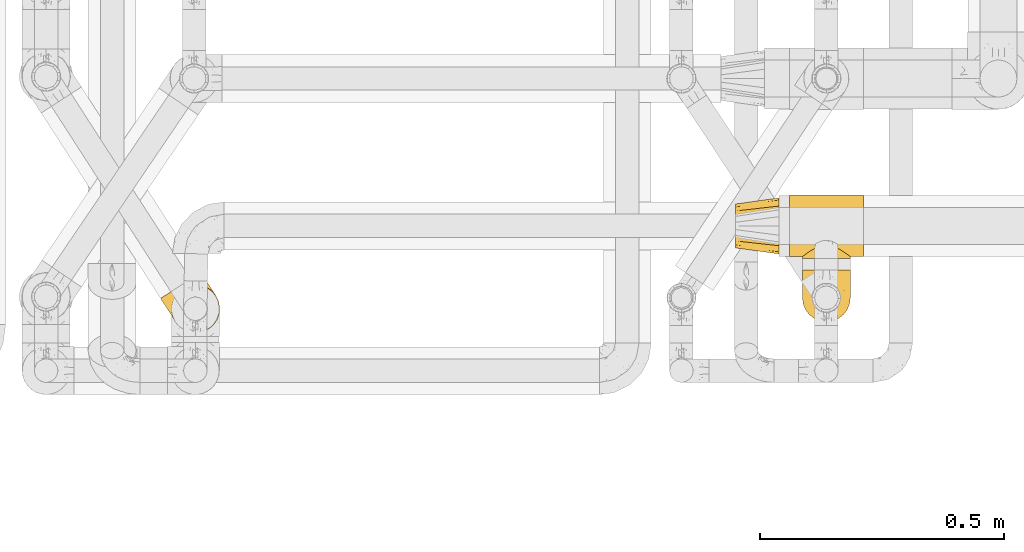
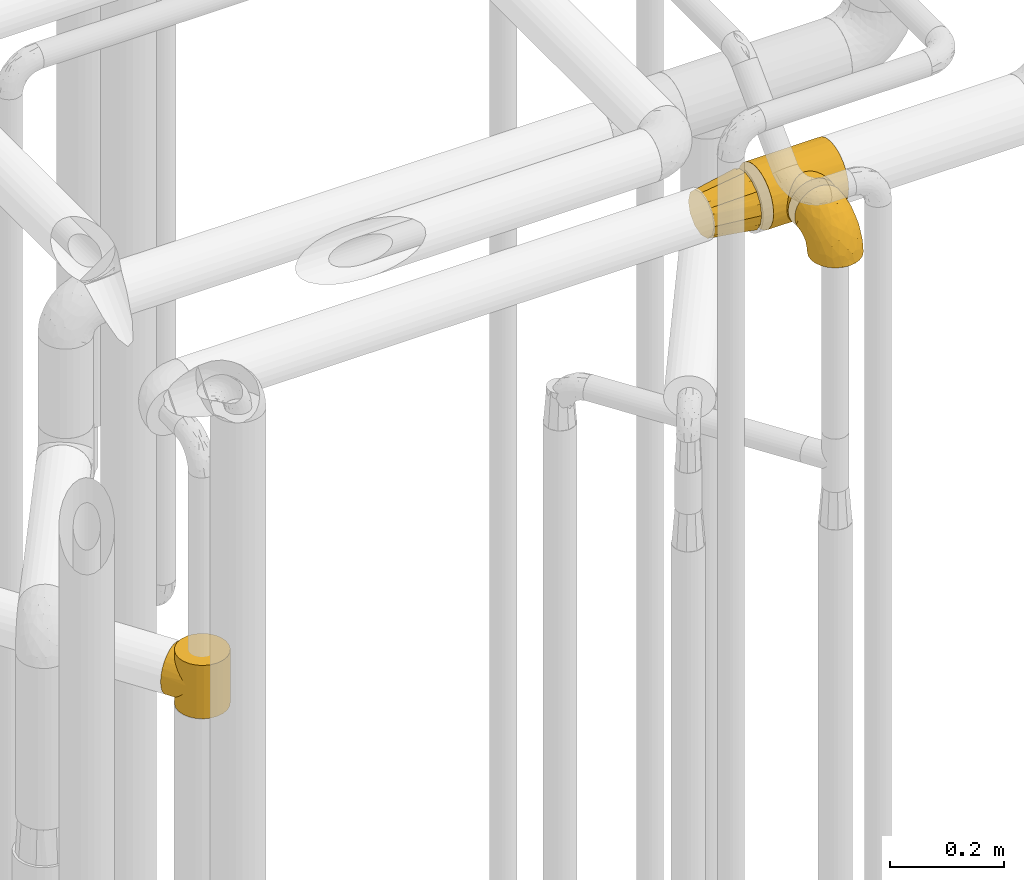
# One storey, part 388 of 827: 4 coverings.
"""IFC2X3 building model written with IfcOpenShell, lengths in millimetres."""

from ifc_helpers import new_model, entity, si_unit, converted_unit, derived_unit, direction, frame, origin, place, context, subcontext, project, spatial, faceted_brep, element, save


model = new_model("IFC2X3")

# Units and contexts
model_context = context("Model", 3, precision=0.01, world=origin(), true_north=direction((6.12303176911189e-17, 1.0)))
body_context = subcontext(model_context, "Body", "Model", "MODEL_VIEW")
ifc_project = project(units=[si_unit("LENGTHUNIT", "METRE", prefix="MILLI"), si_unit("AREAUNIT", "SQUARE_METRE"), si_unit("VOLUMEUNIT", "CUBIC_METRE"), converted_unit("PLANEANGLEUNIT", "DEGREE", entity("IfcRatioMeasure", 0.0174532925199433), si_unit("PLANEANGLEUNIT", "RADIAN"), dimensions=[0, 0, 0, 0, 0, 0, 0]), si_unit("MASSUNIT", "GRAM", prefix="KILO"), derived_unit("MASSDENSITYUNIT", [(si_unit("MASSUNIT", "GRAM", prefix="KILO"), 1), (si_unit("LENGTHUNIT", "METRE"), -3)]), derived_unit("MOMENTOFINERTIAUNIT", [(si_unit("LENGTHUNIT", "METRE"), 4)]), si_unit("TIMEUNIT", "SECOND"), si_unit("FREQUENCYUNIT", "HERTZ"), si_unit("THERMODYNAMICTEMPERATUREUNIT", "DEGREE_CELSIUS"), derived_unit("THERMALTRANSMITTANCEUNIT", [(si_unit("MASSUNIT", "GRAM", prefix="KILO"), 1), (si_unit("THERMODYNAMICTEMPERATUREUNIT", "KELVIN"), -1), (si_unit("TIMEUNIT", "SECOND"), -3)]), derived_unit("VOLUMETRICFLOWRATEUNIT", [(si_unit("LENGTHUNIT", "METRE"), 3), (si_unit("TIMEUNIT", "SECOND"), -1)]), derived_unit("MASSFLOWRATEUNIT", [(si_unit("MASSUNIT", "GRAM", prefix="KILO"), 1), (si_unit("TIMEUNIT", "SECOND"), -1)]), derived_unit("ROTATIONALFREQUENCYUNIT", [(si_unit("TIMEUNIT", "SECOND"), -1)]), si_unit("ELECTRICCURRENTUNIT", "AMPERE"), si_unit("ELECTRICVOLTAGEUNIT", "VOLT"), si_unit("POWERUNIT", "WATT"), si_unit("FORCEUNIT", "NEWTON", prefix="KILO"), si_unit("ILLUMINANCEUNIT", "LUX"), si_unit("LUMINOUSFLUXUNIT", "LUMEN"), si_unit("LUMINOUSINTENSITYUNIT", "CANDELA"), derived_unit("USERDEFINED", [(si_unit("MASSUNIT", "GRAM", prefix="KILO"), -1), (si_unit("LENGTHUNIT", "METRE"), -2), (si_unit("TIMEUNIT", "SECOND"), 3), (si_unit("LUMINOUSFLUXUNIT", "LUMEN"), 1)]), derived_unit("LINEARVELOCITYUNIT", [(si_unit("LENGTHUNIT", "METRE"), 1), (si_unit("TIMEUNIT", "SECOND"), -1)]), si_unit("PRESSUREUNIT", "PASCAL"), derived_unit("USERDEFINED", [(si_unit("LENGTHUNIT", "METRE"), -2), (si_unit("MASSUNIT", "GRAM", prefix="KILO"), 1), (si_unit("TIMEUNIT", "SECOND"), -2)]), derived_unit("LINEARFORCEUNIT", [(si_unit("MASSUNIT", "GRAM", prefix="KILO"), 1), (si_unit("LENGTHUNIT", "METRE"), 1), (si_unit("TIMEUNIT", "SECOND"), -2), (si_unit("LENGTHUNIT", "METRE"), -1)]), derived_unit("PLANARFORCEUNIT", [(si_unit("MASSUNIT", "GRAM", prefix="KILO"), 1), (si_unit("LENGTHUNIT", "METRE"), 1), (si_unit("TIMEUNIT", "SECOND"), -2), (si_unit("LENGTHUNIT", "METRE"), -2)])], contexts=[model_context])

# Site, building, storey
site_placement = place(None, origin())
site = spatial("IfcSite", under=ifc_project, at=site_placement, CompositionType="ELEMENT")
building_placement = place(site_placement, origin())
building = spatial("IfcBuilding", under=site, at=building_placement, CompositionType="ELEMENT")
storey_placement = place(building_placement, frame((0.0, 0.0, 28200.0)))
storey = spatial("IfcBuildingStorey", under=building, at=storey_placement, Name="08", CompositionType="ELEMENT", Elevation=28200.0)

# Coverings
covering_1_placement = place(storey_placement, frame((48106.03, 13874.41, 2538.4)))
element("IfcCovering", 1, at=covering_1_placement, inside=storey, Name=":ADSK_", ObjectType=":ADSK_", PredefinedType="INSULATION", context=body_context, shape_type="Brep", body=[
    faceted_brep([(0.0, 104.1, 59.1), (0.0, 101.08, 47.85), (0.0, 98.07, 36.6), (0.0, 89.83, 28.36), (0.0, 81.6, 20.12), (0.0, 70.35, 17.11), (0.0, 59.1, 14.1), (0.0, 47.85, 17.11), (0.0, 36.6, 20.12), (0.0, 28.36, 28.36), (0.0, 20.12, 36.6), (0.0, 17.11, 47.85), (0.0, 14.1, 59.1), (0.0, 17.11, 70.35), (0.0, 20.12, 81.6), (0.0, 28.36, 89.83), (0.0, 36.6, 98.07), (0.0, 47.85, 101.08), (0.0, 59.1, 104.1), (0.0, 70.35, 101.08), (0.0, 81.6, 98.07), (0.0, 89.83, 89.83), (0.0, 98.07, 81.6), (0.0, 101.08, 70.35), (89.0, 5.97, 81.1), (89.0, 3.78, 70.1), (89.0, 1.6, 59.1), (89.0, 3.78, 48.09), (89.0, 5.97, 37.09), (89.0, 12.2, 27.76), (89.0, 18.44, 18.44), (89.0, 27.76, 12.2), (89.0, 37.09, 5.97), (89.0, 48.09, 3.78), (89.0, 59.1, 1.6), (89.0, 70.1, 3.78), (89.0, 81.1, 5.97), (89.0, 90.43, 12.2), (89.0, 99.75, 18.44), (89.0, 105.99, 27.76), (89.0, 112.22, 37.09), (89.0, 114.41, 48.09), (89.0, 116.6, 59.1), (89.0, 114.41, 70.1), (89.0, 112.22, 81.1), (89.0, 105.99, 90.43), (89.0, 99.75, 99.75), (89.0, 90.43, 105.99), (89.0, 81.1, 112.22), (89.0, 70.1, 114.41), (89.0, 59.1, 116.6), (89.0, 48.09, 114.41), (89.0, 37.09, 112.22), (89.0, 27.76, 105.99), (89.0, 18.44, 99.75), (89.0, 12.2, 90.43)], [[[0, 1, 2, 3, 4, 5, 6, 7, 8, 9, 10, 11, 12, 13, 14, 15, 16, 17, 18, 19, 20, 21, 22, 23]], [[24, 25, 26, 27, 28, 29, 30, 31, 32, 33, 34, 35, 36, 37, 38, 39, 40, 41, 42, 43, 44, 45, 46, 47, 48, 49, 50, 51, 52, 53, 54, 55]], [[35, 34, 6]], [[2, 40, 39]], [[37, 36, 4]], [[37, 4, 3]], [[2, 39, 3]], [[37, 3, 38]], [[41, 40, 1]], [[6, 5, 35]], [[39, 38, 3]], [[0, 41, 1]], [[5, 4, 36]], [[41, 0, 42]], [[40, 2, 1]], [[5, 36, 35]], [[27, 26, 12]], [[8, 32, 31]], [[29, 28, 10]], [[29, 10, 9]], [[8, 31, 9]], [[29, 9, 30]], [[33, 32, 7]], [[12, 11, 27]], [[31, 30, 9]], [[6, 33, 7]], [[11, 10, 28]], [[33, 6, 34]], [[32, 8, 7]], [[11, 28, 27]], [[51, 50, 18]], [[14, 24, 55]], [[53, 52, 16]], [[53, 16, 15]], [[14, 55, 15]], [[53, 15, 54]], [[25, 24, 13]], [[18, 17, 51]], [[55, 54, 15]], [[12, 25, 13]], [[17, 16, 52]], [[25, 12, 26]], [[24, 14, 13]], [[17, 52, 51]], [[43, 42, 0]], [[20, 48, 47]], [[45, 44, 22]], [[45, 22, 21]], [[20, 47, 21]], [[45, 21, 46]], [[49, 48, 19]], [[0, 23, 43]], [[47, 46, 21]], [[18, 49, 19]], [[23, 22, 44]], [[49, 18, 50]], [[48, 20, 19]], [[23, 44, 43]]]),
])
covering_2_placement = place(storey_placement, frame((48216.02, 13866.51, 2532.85)))
element("IfcCovering", 2, at=covering_2_placement, inside=storey, Name=":ADSK_", ObjectType=":ADSK_", PredefinedType="INSULATION", context=body_context, shape_type="Brep", body=[
    faceted_brep([(152.0, 121.6, 33.12), (152.0, 127.9, 48.33), (152.0, 130.05, 64.65), (152.0, 127.9, 80.96), (152.0, 121.6, 96.17), (152.0, 111.58, 109.23), (152.0, 98.53, 119.25), (152.0, 83.32, 125.55), (152.0, 67.0, 127.7), (152.0, 50.68, 125.55), (152.0, 35.48, 119.25), (152.0, 22.42, 109.23), (152.0, 17.41, 102.7), (152.0, 12.4, 96.17), (152.0, 9.25, 88.57), (152.0, 6.1, 80.96), (152.0, 5.02, 72.8), (152.0, 3.95, 64.65), (152.0, 5.02, 56.49), (152.0, 6.1, 48.33), (152.0, 9.25, 40.72), (152.0, 12.4, 33.12), (152.0, 17.41, 26.59), (152.0, 22.42, 20.06), (152.0, 35.48, 10.04), (152.0, 50.68, 3.74), (152.0, 67.0, 1.6), (152.0, 83.32, 3.74), (152.0, 98.53, 10.04), (152.0, 111.58, 20.06), (0.0, 67.0, 127.7), (0.0, 83.32, 125.55), (0.0, 98.53, 119.25), (0.0, 111.58, 109.23), (0.0, 121.6, 96.17), (0.0, 127.9, 80.96), (0.0, 130.05, 64.65), (0.0, 127.9, 48.33), (0.0, 121.6, 33.12), (0.0, 111.58, 20.06), (0.0, 98.53, 10.04), (0.0, 83.32, 3.74), (0.0, 67.0, 1.6), (0.0, 50.68, 3.74), (0.0, 35.48, 10.04), (0.0, 22.42, 20.06), (0.0, 17.41, 26.59), (0.0, 12.4, 33.12), (0.0, 9.25, 40.72), (0.0, 6.1, 48.33), (0.0, 5.02, 56.49), (0.0, 3.95, 64.65), (0.0, 5.02, 72.8), (0.0, 6.1, 80.96), (0.0, 9.25, 88.57), (0.0, 12.4, 96.17), (0.0, 17.41, 102.7), (0.0, 22.42, 109.23), (0.0, 35.48, 119.25), (0.0, 50.68, 125.55), (45.43, 17.06, 103.13), (54.33, 21.96, 108.76), (37.94, 12.15, 95.74), (119.94, 7.92, 86.67), (64.61, 25.9, 112.46), (76.0, 27.51, 113.8), (87.39, 25.9, 112.46), (124.47, 4.48, 70.38), (125.15, 3.95, 64.65), (26.85, 3.95, 64.65), (27.53, 4.48, 70.38), (106.57, 17.06, 103.13), (97.67, 21.96, 108.76), (114.06, 12.15, 95.74), (32.06, 7.92, 86.67), (121.87, 6.46, 81.39), (123.79, 5.0, 76.12), (28.21, 5.0, 76.12), (30.13, 6.46, 81.39), (27.53, 4.48, 58.91), (28.21, 5.0, 53.17), (37.94, 12.15, 33.55), (32.06, 7.92, 42.62), (30.13, 6.46, 47.9), (123.79, 5.0, 53.17), (124.47, 4.48, 58.91), (114.06, 12.15, 33.55), (119.94, 7.92, 42.62), (106.57, 17.06, 26.16), (121.87, 6.46, 47.9), (45.43, 17.06, 26.16), (54.33, 21.96, 20.53), (64.61, 25.9, 16.83), (76.0, 27.51, 15.5), (97.67, 21.96, 20.53), (87.39, 25.9, 16.83), (63.28, 0.0, 112.12), (51.43, 0.0, 107.21), (41.25, 0.0, 99.4), (33.43, 0.0, 89.22), (30.98, 0.0, 83.29), (28.52, 0.0, 77.37), (27.69, 0.0, 71.01), (26.85, 0.0, 64.65), (27.69, 0.0, 58.28), (28.52, 0.0, 51.92), (30.98, 0.0, 46.0), (33.43, 0.0, 40.07), (41.25, 0.0, 29.89), (51.43, 0.0, 22.08), (63.28, 0.0, 17.17), (76.0, 0.0, 15.5), (88.72, 0.0, 17.17), (100.58, 0.0, 22.08), (110.75, 0.0, 29.89), (118.57, 0.0, 40.07), (121.02, 0.0, 46.0), (123.48, 0.0, 51.92), (124.31, 0.0, 58.28), (125.15, 0.0, 64.65), (124.31, 0.0, 71.01), (123.48, 0.0, 77.37), (121.02, 0.0, 83.29), (118.57, 0.0, 89.22), (110.75, 0.0, 99.4), (100.58, 0.0, 107.21), (88.72, 0.0, 112.12), (76.0, 0.0, 113.8)], [[[0, 1, 2, 3, 4, 5, 6, 7, 8, 9, 10, 11, 12, 13, 14, 15, 16, 17, 18, 19, 20, 21, 22, 23, 24, 25, 26, 27, 28, 29]], [[30, 31, 32, 33, 34, 35, 36, 37, 38, 39, 40, 41, 42, 43, 44, 45, 46, 47, 48, 49, 50, 51, 52, 53, 54, 55, 56, 57, 58, 59]], [[34, 33, 5, 4]], [[2, 36, 35, 3]], [[4, 3, 35, 34]], [[6, 32, 31, 7]], [[7, 31, 30, 8]], [[5, 33, 32, 6]], [[59, 9, 8, 30]], [[58, 10, 9, 59]], [[57, 60, 61]], [[56, 55, 62]], [[63, 15, 14]], [[61, 64, 57]], [[60, 57, 56]], [[57, 64, 58]], [[64, 65, 58]], [[66, 11, 10]], [[17, 67, 68]], [[69, 70, 51]], [[71, 11, 72]], [[72, 11, 66]], [[73, 12, 71]], [[66, 10, 65]], [[65, 10, 58]], [[62, 54, 74]], [[54, 62, 55]], [[74, 54, 53]], [[15, 63, 75, 76]], [[77, 53, 52]], [[51, 70, 52]], [[77, 52, 70]], [[53, 77, 78, 74]], [[73, 13, 12]], [[73, 14, 13]], [[14, 73, 63]], [[16, 76, 67]], [[71, 12, 11]], [[17, 16, 67]], [[16, 15, 76]], [[60, 56, 62]], [[50, 79, 51]], [[80, 50, 49]], [[47, 81, 48]], [[82, 48, 81]], [[82, 49, 48]], [[49, 82, 83, 80]], [[50, 80, 79]], [[84, 18, 85]], [[85, 17, 68]], [[51, 79, 69]], [[86, 21, 20]], [[17, 85, 18]], [[20, 19, 87]], [[86, 88, 22]], [[87, 19, 84, 89]], [[81, 46, 90]], [[81, 47, 46]], [[90, 45, 91]], [[45, 90, 46]], [[91, 45, 92]], [[24, 44, 43, 25]], [[93, 92, 44]], [[44, 92, 45]], [[43, 42, 26, 25]], [[84, 19, 18]], [[94, 95, 23]], [[86, 20, 87]], [[22, 21, 86]], [[23, 88, 94]], [[95, 24, 23]], [[93, 24, 95]], [[93, 44, 24]], [[88, 23, 22]], [[27, 41, 40, 28]], [[28, 40, 39, 29]], [[42, 41, 27, 26]], [[0, 38, 37, 1]], [[1, 37, 36, 2]], [[29, 39, 38, 0]], [[96, 97, 98, 99, 100, 101, 102, 103, 104, 105, 106, 107, 108, 109, 110, 111, 112, 113, 114, 115, 116, 117, 118, 119, 120, 121, 122, 123, 124, 125, 126, 127]], [[77, 102, 101]], [[74, 100, 99]], [[103, 70, 69]], [[103, 102, 70]], [[101, 78, 77]], [[62, 74, 99]], [[100, 78, 101]], [[100, 74, 78]], [[99, 98, 62]], [[60, 98, 97]], [[96, 127, 64]], [[102, 77, 70]], [[61, 97, 96]], [[60, 97, 61]], [[64, 61, 96]], [[65, 64, 127]], [[98, 60, 62]], [[66, 127, 126]], [[72, 126, 125]], [[65, 127, 66]], [[119, 67, 120]], [[66, 126, 72]], [[125, 71, 72]], [[125, 124, 71]], [[73, 124, 123]], [[76, 75, 121]], [[67, 119, 68]], [[76, 121, 120]], [[63, 73, 123]], [[63, 123, 122]], [[76, 120, 67]], [[122, 75, 63]], [[121, 75, 122]], [[124, 73, 71]], [[84, 118, 117]], [[87, 116, 115]], [[119, 85, 68]], [[119, 118, 85]], [[117, 89, 84]], [[86, 87, 115]], [[116, 89, 117]], [[118, 84, 85]], [[115, 114, 86]], [[88, 114, 113]], [[113, 112, 94]], [[111, 95, 112]], [[116, 87, 89]], [[88, 113, 94]], [[95, 94, 112]], [[93, 95, 111]], [[114, 88, 86]], [[92, 111, 110]], [[91, 110, 109]], [[93, 111, 92]], [[103, 79, 104]], [[92, 110, 91]], [[109, 90, 91]], [[109, 108, 90]], [[81, 108, 107]], [[80, 83, 105]], [[79, 103, 69]], [[80, 105, 104]], [[82, 81, 107]], [[82, 107, 106]], [[80, 104, 79]], [[106, 83, 82]], [[105, 83, 106]], [[108, 81, 90]]]),
])
covering_3_placement = place(storey_placement, frame((48241.28, 13735.35, 2538.9)))
element("IfcCovering", 3, at=covering_3_placement, inside=storey, Name=":ADSK_", ObjectType=":ADSK_", PredefinedType="INSULATION", context=body_context, shape_type="Brep", body=[
    faceted_brep([(1.6, 107.75, 58.6), (2.83, 107.75, 69.54), (6.47, 107.75, 79.93), (12.32, 107.75, 89.25), (20.11, 107.75, 97.03), (29.43, 107.75, 102.88), (39.81, 107.75, 106.51), (50.75, 107.75, 107.75), (61.69, 107.75, 106.51), (72.08, 107.75, 102.87), (81.4, 107.75, 97.02), (89.18, 107.75, 89.23), (95.03, 107.75, 79.91), (98.66, 107.75, 69.53), (99.9, 107.75, 58.6), (99.25, 107.75, 52.89), (98.66, 107.75, 47.65), (96.84, 107.75, 42.46), (95.02, 107.75, 37.26), (89.17, 107.75, 27.94), (81.38, 107.75, 20.16), (72.06, 107.75, 14.31), (61.68, 107.75, 10.68), (50.75, 107.75, 9.45), (39.8, 107.75, 10.68), (29.41, 107.75, 14.32), (20.09, 107.75, 20.17), (12.31, 107.75, 27.96), (6.46, 107.75, 37.28), (4.64, 107.75, 42.47), (2.83, 107.75, 47.66), (2.24, 107.75, 52.89), (1.92, 107.75, 55.75), (63.47, 98.22, 1.6), (75.32, 93.31, 1.6), (80.41, 89.4, 1.6), (85.5, 85.5, 1.6), (89.4, 80.41, 1.6), (93.31, 75.32, 1.6), (95.77, 69.39, 1.6), (98.22, 63.47, 1.6), (99.14, 56.48, 1.6), (99.52, 53.61, 1.6), (99.9, 50.75, 1.6), (98.22, 38.02, 1.6), (93.31, 26.17, 1.6), (85.5, 15.99, 1.6), (75.32, 8.18, 1.6), (63.47, 3.27, 1.6), (50.75, 1.6, 1.6), (38.02, 3.27, 1.6), (26.17, 8.18, 1.6), (15.99, 15.99, 1.6), (8.18, 26.17, 1.6), (3.27, 38.02, 1.6), (1.6, 50.75, 1.6), (2.35, 56.48, 1.6), (3.27, 63.47, 1.6), (5.73, 69.39, 1.6), (8.18, 75.32, 1.6), (12.09, 80.41, 1.6), (15.99, 85.5, 1.6), (21.08, 89.4, 1.6), (26.17, 93.31, 1.6), (38.02, 98.22, 1.6), (50.75, 99.9, 1.6), (42.18, 27.53, 69.96), (28.42, 25.32, 59.59), (37.78, 16.29, 51.96), (50.75, 6.79, 34.4), (42.85, 4.51, 23.37), (50.75, 3.51, 13.68), (24.75, 17.47, 41.52), (33.81, 7.6, 26.26), (22.57, 12.27, 20.18), (7.18, 70.89, 72.33), (2.73, 87.17, 65.88), (3.09, 67.3, 57.55), (6.92, 31.65, 23.76), (11.58, 33.58, 46.5), (5.17, 47.23, 46.57), (2.71, 43.26, 21.17), (1.6, 55.08, 23.41), (1.6, 53.99, 17.92), (1.6, 52.9, 12.43), (1.6, 52.36, 9.72), (1.6, 51.82, 7.01), (14.18, 21.5, 26.77), (5.88, 89.94, 76.59), (41.06, 60.45, 95.55), (36.25, 83.0, 102.57), (28.62, 64.79, 92.89), (1.6, 85.93, 54.26), (1.6, 81.31, 51.17), (1.6, 76.69, 48.08), (1.6, 72.06, 44.99), (1.6, 67.44, 41.9), (10.85, 88.74, 85.16), (38.35, 45.98, 85.97), (9.6, 47.13, 59.58), (26.24, 89.4, 99.5), (50.75, 95.66, 105.83), (19.31, 28.5, 53.59), (16.41, 42.81, 67.0), (24.56, 38.28, 71.56), (50.75, 45.35, 87.47), (50.75, 33.61, 75.73), (18.47, 82.57, 92.24), (1.6, 105.04, 58.06), (1.6, 102.33, 57.52), (1.6, 96.91, 56.44), (1.6, 91.42, 55.35), (14.36, 65.92, 81.33), (20.64, 53.11, 80.35), (2.32, 54.37, 39.44), (50.75, 74.94, 102.55), (1.6, 64.35, 37.28), (1.6, 61.26, 32.65), (1.6, 58.17, 28.03), (50.75, 21.87, 63.99), (33.88, 34.79, 74.55), (29.24, 48.48, 83.62), (50.75, 60.15, 95.01), (50.75, 14.33, 49.19), (2.8, 99.07, 46.96), (2.48, 60.55, 8.77), (2.7, 64.18, 18.28), (3.2, 64.36, 11.68), (32.98, 103.17, 11.79), (24.67, 101.69, 15.69), (2.95, 87.75, 42.49), (2.19, 89.38, 47.41), (17.92, 88.34, 7.94), (12.02, 82.14, 9.27), (25.73, 94.51, 7.98), (16.63, 89.64, 13.4), (25.6, 98.41, 13.04), (36.72, 99.71, 7.36), (10.66, 89.37, 23.46), (6.87, 88.21, 30.46), (11.12, 95.2, 26.54), (10.31, 79.14, 6.76), (12.84, 101.22, 26.46), (17.38, 99.41, 20.77), (9.74, 84.72, 20.68), (4.63, 97.47, 40.26), (50.75, 102.19, 7.15), (42.52, 104.02, 9.28), (3.12, 82.66, 38.78), (17.58, 95.42, 18.27), (3.97, 78.67, 31.78), (5.94, 72.69, 12.75), (2.73, 66.46, 22.96), (6.23, 75.3, 17.55), (3.45, 72.74, 27.63), (10.84, 82.93, 15.23), (7.98, 99.27, 33.25), (7.33, 93.51, 32.43), (2.39, 67.35, 27.9), (75.76, 94.51, 7.97), (90.65, 82.94, 15.22), (83.57, 88.33, 7.93), (84.85, 89.64, 13.38), (71.05, 103.62, 13.12), (98.54, 87.74, 42.49), (99.3, 89.38, 47.4), (99.9, 81.31, 51.17), (96.86, 97.47, 40.24), (84.1, 99.41, 20.76), (99.9, 51.28, 4.31), (99.9, 52.9, 12.43), (99.9, 51.82, 7.01), (88.63, 101.21, 26.44), (90.36, 95.19, 26.52), (98.29, 64.36, 11.68), (95.55, 72.69, 12.75), (89.47, 82.13, 9.27), (95.26, 75.3, 17.55), (91.18, 79.14, 6.76), (93.49, 99.28, 33.21), (94.15, 93.51, 32.41), (99.01, 60.55, 8.77), (98.76, 66.46, 22.96), (98.85, 63.96, 18.48), (99.9, 96.91, 56.44), (98.69, 99.06, 46.95), (64.78, 99.7, 7.36), (99.9, 53.99, 17.92), (99.9, 55.08, 23.41), (62.91, 103.3, 9.85), (99.9, 102.33, 57.52), (99.9, 99.62, 56.98), (99.9, 76.69, 48.08), (98.37, 82.66, 38.78), (83.9, 95.42, 18.25), (99.9, 72.06, 44.99), (97.51, 78.68, 31.74), (94.62, 88.2, 30.45), (98.04, 72.75, 27.63), (91.73, 84.74, 20.65), (99.9, 91.42, 55.35), (99.9, 85.93, 54.26), (75.87, 98.41, 13.03), (90.83, 89.37, 23.44), (99.1, 67.35, 27.9), (99.9, 61.26, 32.65), (99.9, 58.17, 28.03), (99.9, 64.35, 37.28), (99.9, 67.44, 41.9), (99.09, 54.08, 39.74), (58.64, 4.51, 23.37), (87.31, 21.5, 26.77), (89.93, 33.43, 46.18), (82.22, 28.5, 53.54), (76.74, 17.47, 41.53), (73.12, 25.36, 59.61), (95.54, 90.18, 76.79), (98.7, 86.97, 66.11), (98.79, 43.26, 21.17), (63.71, 16.29, 51.96), (67.68, 7.6, 26.26), (78.92, 12.27, 20.18), (94.57, 31.65, 23.76), (72.88, 64.79, 92.88), (65.25, 83.0, 102.57), (60.44, 60.44, 95.54), (76.94, 38.35, 71.63), (67.61, 34.8, 74.55), (94.38, 71.54, 72.51), (63.11, 45.94, 85.95), (59.31, 27.53, 69.96), (83.03, 82.57, 92.23), (90.66, 88.74, 85.15), (80.8, 53.19, 80.45), (72.22, 48.49, 83.65), (98.39, 67.28, 57.57), (92.31, 52.32, 63.68), (75.27, 89.4, 99.49), (87.15, 65.75, 81.23), (96.03, 46.73, 47.07), (85.1, 42.82, 66.99)], [[[0, 1, 2, 3, 4, 5, 6, 7, 8, 9, 10, 11, 12, 13, 14, 15, 16, 17, 18, 19, 20, 21, 22, 23, 24, 25, 26, 27, 28, 29, 30, 31, 32]], [[33, 34, 35, 36, 37, 38, 39, 40, 41, 42, 43, 44, 45, 46, 47, 48, 49, 50, 51, 52, 53, 54, 55, 56, 57, 58, 59, 60, 61, 62, 63, 64, 65]], [[66, 67, 68]], [[69, 70, 71]], [[68, 72, 73]], [[73, 72, 74]], [[75, 76, 77]], [[78, 79, 80]], [[51, 50, 73]], [[81, 82, 83, 84, 85, 86, 55]], [[52, 87, 53]], [[74, 52, 51]], [[2, 1, 88]], [[89, 90, 91]], [[77, 92, 93, 94, 95, 96]], [[55, 54, 81]], [[78, 53, 87]], [[5, 90, 6]], [[88, 76, 75]], [[97, 3, 2]], [[89, 91, 98]], [[99, 80, 79]], [[90, 5, 100]], [[74, 87, 52]], [[100, 5, 4]], [[90, 101, 6]], [[79, 102, 103]], [[102, 67, 104]], [[105, 98, 106]], [[107, 4, 3]], [[76, 0, 108, 109, 110, 111, 92]], [[107, 112, 113]], [[114, 77, 96]], [[89, 115, 90]], [[114, 96, 116, 117, 118, 82]], [[75, 97, 88]], [[119, 66, 68]], [[50, 71, 70]], [[100, 91, 90]], [[99, 77, 80]], [[102, 104, 103]], [[97, 107, 3]], [[80, 81, 78]], [[107, 97, 112]], [[68, 73, 70]], [[66, 98, 120]], [[78, 81, 54]], [[114, 81, 80]], [[53, 78, 54]], [[78, 87, 79]], [[102, 87, 72]], [[79, 103, 99]], [[4, 107, 100]], [[91, 100, 107]], [[88, 97, 2]], [[112, 97, 75]], [[99, 112, 75]], [[103, 104, 113]], [[91, 121, 98]], [[89, 105, 122, 115]], [[101, 90, 115]], [[101, 7, 6]], [[88, 1, 76]], [[0, 76, 1]], [[92, 77, 76]], [[73, 74, 51]], [[87, 74, 72]], [[81, 114, 82]], [[77, 114, 80]], [[87, 102, 79]], [[67, 102, 72]], [[68, 67, 72]], [[67, 120, 104]], [[120, 121, 104]], [[104, 121, 113]], [[121, 120, 98]], [[91, 107, 113]], [[91, 113, 121]], [[103, 113, 112]], [[66, 119, 106]], [[105, 89, 98]], [[68, 69, 123, 119]], [[98, 66, 106]], [[66, 120, 67]], [[50, 49, 71]], [[50, 70, 73]], [[112, 99, 103]], [[77, 99, 75]], [[69, 68, 70]], [[29, 124, 110]], [[84, 83, 125]], [[126, 82, 118]], [[59, 58, 127]], [[25, 128, 129]], [[130, 93, 131]], [[132, 62, 133]], [[134, 135, 136]], [[137, 65, 64]], [[64, 134, 137]], [[138, 139, 140]], [[111, 110, 124, 92]], [[134, 136, 137]], [[134, 64, 63]], [[141, 61, 60]], [[125, 58, 57]], [[142, 143, 140]], [[142, 26, 143]], [[127, 83, 82]], [[28, 124, 29]], [[108, 0, 32, 31, 30, 110, 109]], [[30, 29, 110]], [[135, 144, 138]], [[28, 145, 124]], [[57, 56, 55, 86, 85, 84]], [[146, 147, 23]], [[24, 23, 147]], [[25, 143, 26]], [[95, 94, 148]], [[24, 128, 25]], [[149, 138, 143]], [[124, 145, 131]], [[127, 58, 125]], [[150, 148, 139]], [[127, 126, 151]], [[151, 59, 127]], [[152, 151, 126]], [[153, 154, 155]], [[153, 133, 141]], [[145, 28, 27]], [[142, 156, 27]], [[157, 148, 130]], [[61, 133, 62]], [[134, 132, 135]], [[147, 128, 24]], [[65, 137, 146]], [[146, 137, 147]], [[128, 137, 136]], [[137, 128, 147]], [[128, 136, 129]], [[149, 129, 136]], [[25, 129, 143]], [[158, 152, 117]], [[152, 118, 117]], [[153, 151, 152]], [[158, 116, 154]], [[144, 150, 138]], [[153, 152, 158]], [[133, 153, 155]], [[133, 155, 132]], [[60, 151, 141]], [[135, 132, 155]], [[134, 63, 132]], [[144, 135, 155]], [[135, 138, 149]], [[155, 154, 144]], [[150, 154, 96]], [[154, 150, 144]], [[148, 94, 130]], [[82, 126, 127]], [[118, 152, 126]], [[150, 96, 95]], [[139, 148, 157]], [[150, 95, 148]], [[93, 92, 131]], [[130, 145, 156]], [[130, 94, 93]], [[84, 125, 57]], [[127, 125, 83]], [[140, 139, 157]], [[150, 139, 138]], [[140, 157, 142]], [[138, 140, 143]], [[156, 142, 157]], [[27, 26, 142]], [[130, 156, 157]], [[145, 27, 156]], [[132, 63, 62]], [[124, 131, 92]], [[130, 131, 145]], [[129, 149, 143]], [[135, 149, 136]], [[141, 133, 61]], [[60, 59, 151]], [[141, 151, 153]], [[116, 96, 154]], [[153, 158, 154]], [[158, 117, 116]], [[34, 33, 159]], [[160, 161, 162]], [[22, 21, 163]], [[164, 165, 166]], [[19, 18, 167]], [[168, 21, 20]], [[169, 43, 42, 41, 40, 170, 171]], [[172, 173, 168]], [[174, 38, 175]], [[176, 177, 178]], [[179, 164, 180]], [[40, 181, 170]], [[182, 183, 175]], [[17, 184, 185]], [[65, 146, 186]], [[187, 174, 188]], [[23, 22, 189]], [[174, 39, 38]], [[15, 14, 190, 191, 184, 16]], [[181, 40, 39]], [[192, 193, 164]], [[194, 163, 168]], [[33, 186, 159]], [[180, 173, 172]], [[195, 196, 193]], [[18, 185, 167]], [[173, 180, 197]], [[198, 199, 196]], [[200, 201, 185, 184]], [[184, 17, 16]], [[18, 17, 185]], [[202, 159, 186]], [[194, 168, 203]], [[189, 163, 202]], [[204, 205, 182]], [[187, 181, 174]], [[160, 177, 176]], [[206, 183, 182]], [[206, 182, 205]], [[201, 165, 185]], [[165, 164, 167]], [[172, 179, 180]], [[202, 194, 162]], [[176, 161, 160]], [[65, 186, 33]], [[163, 189, 22]], [[175, 177, 182]], [[174, 183, 188]], [[177, 198, 204]], [[199, 160, 162]], [[198, 207, 204]], [[175, 38, 37]], [[198, 177, 160]], [[178, 177, 175]], [[176, 35, 161]], [[34, 159, 161]], [[162, 161, 159]], [[202, 162, 159]], [[199, 162, 203]], [[196, 199, 203]], [[198, 160, 199]], [[193, 197, 180]], [[208, 198, 196]], [[188, 183, 206]], [[175, 183, 174]], [[193, 192, 195]], [[195, 208, 196]], [[197, 196, 203]], [[180, 164, 193]], [[168, 163, 21]], [[166, 165, 201]], [[166, 192, 164]], [[189, 202, 186]], [[186, 146, 189]], [[23, 189, 146]], [[174, 181, 39]], [[170, 181, 187]], [[196, 197, 193]], [[173, 203, 168]], [[203, 173, 197]], [[172, 168, 20]], [[20, 19, 172]], [[179, 172, 19]], [[19, 167, 179]], [[164, 179, 167]], [[35, 176, 36]], [[35, 34, 161]], [[185, 165, 167]], [[162, 194, 203]], [[163, 194, 202]], [[176, 178, 36]], [[37, 36, 178]], [[175, 37, 178]], [[177, 204, 182]], [[207, 198, 208]], [[207, 205, 204]], [[209, 188, 206, 205, 207, 208]], [[48, 210, 71]], [[211, 212, 213]], [[214, 213, 215]], [[216, 217, 13]], [[218, 43, 169, 171, 170, 187, 188]], [[219, 220, 214]], [[47, 46, 221]], [[210, 48, 220]], [[211, 222, 212]], [[222, 45, 44]], [[221, 220, 47]], [[47, 220, 48]], [[221, 211, 214]], [[223, 224, 225]], [[211, 46, 45]], [[226, 227, 215]], [[43, 218, 44]], [[217, 216, 228]], [[227, 229, 230]], [[14, 13, 217]], [[224, 9, 8]], [[10, 231, 11]], [[11, 232, 12]], [[233, 223, 234]], [[235, 208, 195, 192, 166, 201]], [[236, 235, 228]], [[222, 44, 218]], [[106, 230, 229]], [[224, 237, 9]], [[232, 238, 228]], [[9, 237, 10]], [[115, 224, 101]], [[239, 235, 236]], [[232, 11, 231]], [[223, 231, 237]], [[224, 8, 101]], [[223, 229, 234]], [[225, 115, 122, 105]], [[216, 12, 232]], [[209, 235, 239]], [[210, 219, 69]], [[219, 214, 215]], [[230, 119, 219]], [[209, 218, 188]], [[239, 212, 222]], [[239, 222, 218]], [[45, 222, 211]], [[236, 212, 239]], [[213, 212, 240]], [[223, 237, 224]], [[231, 10, 237]], [[238, 232, 231]], [[216, 232, 228]], [[233, 231, 223]], [[236, 238, 240]], [[115, 225, 224]], [[234, 229, 227]], [[8, 7, 101]], [[235, 209, 208]], [[218, 209, 239]], [[217, 228, 235]], [[13, 12, 216]], [[235, 201, 217]], [[217, 201, 200, 184, 191, 190, 14]], [[211, 221, 46]], [[220, 221, 214]], [[71, 210, 69]], [[71, 49, 48]], [[219, 210, 220]], [[226, 215, 213]], [[211, 213, 214]], [[226, 213, 240]], [[215, 227, 230]], [[233, 240, 238]], [[234, 227, 226]], [[233, 234, 226]], [[229, 223, 225]], [[240, 233, 226]], [[233, 238, 231]], [[225, 105, 229]], [[229, 105, 106]], [[106, 119, 230]], [[123, 69, 219, 119]], [[215, 230, 219]], [[238, 236, 228]], [[212, 236, 240]]]),
])
covering_4_placement = place(storey_placement, frame((46925.75, 13713.07, 2043.11)))
element("IfcCovering", 4, at=covering_4_placement, inside=storey, Name=":ADSK_", ObjectType=":ADSK_", PredefinedType="INSULATION", context=body_context, shape_type="Brep", body=[
    faceted_brep([(111.11, 82.72, 50.38), (115.09, 77.41, 0.0), (106.76, 87.17, 0.0), (96.2, 94.45, 0.0), (101.0, 91.64, 37.4), (88.1, 97.72, 25.28), (84.11, 98.75, 0.0), (94.9, 95.09, 31.18), (115.09, 77.41, 57.0), (111.11, 82.72, 63.62), (115.09, 77.41, 114.0), (51.25, 94.08, 8.29), (52.9, 94.68, 0.0), (50.01, 93.31, 0.0), (106.41, 87.49, 43.83), (47.11, 91.93, 7.85), (47.11, 91.93, 0.0), (50.01, 93.31, 114.0), (47.11, 91.93, 106.15), (47.11, 91.93, 114.0), (80.63, 99.36, 19.84), (71.32, 99.77, 0.0), (65.01, 98.6, 0.0), (58.7, 97.44, 0.0), (59.72, 97.54, 10.0), (55.4, 96.24, 8.74), (72.56, 99.81, 15.07), (64.04, 98.84, 11.25), (55.8, 96.06, 0.0), (44.67, 89.85, 0.0), (42.23, 87.77, 0.0), (43.09, 88.67, 8.4), (39.06, 85.41, 8.94), (39.79, 85.68, 0.0), (37.35, 83.6, 0.0), (32.78, 77.69, 12.0), (33.71, 78.32, 0.0), (30.07, 73.04, 0.0), (35.92, 81.55, 10.47), (28.4, 69.41, 16.57), (27.92, 66.99, 0.0), (25.79, 61.03, 22.18), (30.59, 73.55, 14.29), (45.1, 90.3, 8.12), (25.77, 60.95, 0.0), (24.74, 52.82, 28.5), (24.75, 48.16, 0.0), (25.03, 44.92, 35.29), (27.08, 35.54, 0.0), (29.06, 30.42, 49.65), (32.59, 23.95, 0.0), (45.1, 90.3, 105.88), (26.51, 37.43, 42.38), (32.59, 23.95, 57.0), (29.06, 30.42, 64.35), (32.59, 23.95, 114.0), (76.36, 1.6, 114.0), (88.98, 3.92, 114.0), (100.57, 9.43, 114.0), (110.33, 17.76, 114.0), (117.61, 28.32, 114.0), (121.91, 40.41, 114.0), (122.92, 53.2, 114.0), (120.6, 65.82, 114.0), (106.76, 87.17, 114.0), (96.2, 94.45, 114.0), (84.11, 98.75, 114.0), (71.32, 99.77, 114.0), (65.01, 98.6, 114.0), (58.7, 97.44, 114.0), (55.8, 96.06, 114.0), (52.9, 94.68, 114.0), (44.67, 89.85, 114.0), (42.23, 87.77, 114.0), (39.79, 85.68, 114.0), (37.35, 83.6, 114.0), (33.71, 78.32, 114.0), (30.07, 73.04, 114.0), (27.92, 66.99, 114.0), (25.77, 60.95, 114.0), (24.75, 48.16, 114.0), (27.08, 35.54, 114.0), (40.92, 14.19, 114.0), (51.48, 6.91, 114.0), (63.57, 2.61, 114.0), (120.6, 65.82, 0.0), (122.92, 53.2, 0.0), (121.91, 40.41, 0.0), (117.61, 28.32, 0.0), (110.33, 17.76, 0.0), (100.57, 9.43, 0.0), (88.98, 3.92, 0.0), (76.36, 1.6, 0.0), (63.57, 2.61, 0.0), (51.48, 6.91, 0.0), (40.92, 14.19, 0.0), (106.41, 87.49, 70.17), (101.0, 91.64, 76.6), (51.25, 94.08, 105.71), (94.9, 95.09, 82.82), (88.1, 97.72, 88.72), (55.4, 96.24, 105.26), (80.63, 99.36, 94.16), (72.56, 99.81, 98.93), (59.72, 97.54, 104.0), (64.04, 98.84, 102.75), (32.78, 77.69, 102.0), (35.92, 81.55, 103.53), (28.4, 69.41, 97.43), (39.06, 85.41, 105.06), (25.79, 61.03, 91.82), (30.59, 73.55, 99.71), (43.09, 88.67, 105.6), (25.03, 44.92, 78.71), (26.51, 37.43, 71.62), (24.74, 52.82, 85.5), (82.68, 124.33, 44.28), (78.56, 121.66, 32.42), (72.01, 117.42, 22.25), (63.47, 111.88, 14.43), (58.49, 108.66, 11.98), (53.52, 105.43, 9.52), (50.85, 103.7, 9.11), (48.18, 101.97, 8.69), (45.51, 100.24, 8.27), (42.84, 98.52, 7.85), (40.17, 96.79, 8.27), (37.5, 95.06, 8.69), (34.84, 93.33, 9.11), (32.17, 91.6, 9.52), (27.19, 88.37, 11.98), (22.22, 85.15, 14.43), (17.95, 82.38, 18.34), (13.68, 79.62, 22.25), (7.12, 75.37, 32.42), (3.0, 72.7, 44.28), (1.6, 71.79, 57.0), (3.0, 72.7, 69.72), (7.12, 75.37, 81.57), (13.68, 79.62, 91.75), (17.95, 82.38, 95.66), (22.22, 85.15, 99.57), (27.19, 88.37, 102.02), (32.17, 91.6, 104.48), (34.84, 93.33, 104.89), (37.5, 95.06, 105.31), (40.17, 96.79, 105.73), (42.84, 98.52, 106.15), (45.51, 100.24, 105.73), (48.18, 101.97, 105.31), (50.85, 103.7, 104.89), (53.52, 105.43, 104.48), (58.49, 108.66, 102.02), (63.47, 111.88, 99.57), (72.01, 117.42, 91.75), (78.56, 121.66, 81.57), (82.68, 124.33, 69.72), (84.09, 125.24, 57.0)], [[[0, 1, 2]], [[2, 3, 4]], [[5, 3, 6]], [[5, 7, 3]], [[0, 8, 1]], [[8, 9, 10]], [[11, 12, 13]], [[4, 14, 2]], [[7, 4, 3]], [[0, 2, 14]], [[15, 13, 16]], [[17, 18, 19]], [[20, 6, 21]], [[22, 23, 24]], [[15, 11, 13]], [[23, 25, 24]], [[26, 20, 21]], [[27, 21, 22]], [[27, 22, 24]], [[25, 12, 11]], [[25, 23, 28, 12]], [[26, 21, 27]], [[6, 20, 5]], [[29, 30, 31]], [[32, 30, 33, 34]], [[35, 36, 37]], [[38, 36, 35]], [[38, 32, 34]], [[39, 37, 40]], [[41, 39, 40]], [[35, 37, 39, 42]], [[43, 16, 29]], [[40, 44, 41]], [[45, 44, 46]], [[47, 46, 48]], [[49, 48, 50]], [[47, 45, 46]], [[16, 43, 15]], [[51, 19, 18]], [[49, 52, 48]], [[53, 49, 50]], [[54, 53, 55]], [[30, 32, 31]], [[47, 48, 52]], [[36, 38, 34]], [[44, 45, 41]], [[29, 31, 43]], [[56, 57, 58, 59, 60, 61, 62, 63, 10, 64, 65, 66, 67, 68, 69, 70, 71, 17, 19, 72, 73, 74, 75, 76, 77, 78, 79, 80, 81, 55, 82, 83, 84]], [[85, 86, 87, 88, 89, 90, 91, 92, 93, 94, 95, 50, 48, 46, 44, 40, 37, 36, 34, 33, 30, 29, 16, 13, 12, 28, 23, 22, 21, 6, 3, 2, 1]], [[88, 87, 61, 60]], [[58, 90, 89, 59]], [[89, 88, 60, 59]], [[62, 86, 85, 63]], [[1, 8, 10, 63, 85]], [[61, 87, 86, 62]], [[96, 97, 64]], [[18, 17, 98]], [[9, 96, 64]], [[10, 9, 64]], [[65, 99, 100]], [[65, 64, 97]], [[71, 101, 98]], [[65, 100, 66]], [[99, 65, 97]], [[102, 103, 67]], [[104, 68, 105]], [[104, 101, 69]], [[68, 104, 69]], [[103, 105, 67]], [[66, 102, 67]], [[101, 71, 70, 69]], [[68, 67, 105]], [[98, 17, 71]], [[102, 66, 100]], [[106, 76, 107]], [[106, 77, 76]], [[77, 108, 78]], [[109, 75, 74, 73]], [[110, 78, 108]], [[111, 108, 77, 106]], [[19, 51, 72]], [[109, 73, 112]], [[72, 51, 112]], [[76, 75, 107]], [[110, 79, 78]], [[75, 109, 107]], [[113, 114, 81]], [[114, 54, 81]], [[79, 115, 80]], [[115, 79, 110]], [[113, 80, 115]], [[113, 81, 80]], [[54, 55, 81]], [[112, 73, 72]], [[53, 50, 95, 82, 55]], [[82, 95, 94, 83]], [[94, 93, 84, 83]], [[84, 93, 92, 56]], [[56, 92, 91, 57]], [[57, 91, 90, 58]], [[116, 117, 118, 119, 120, 121, 122, 123, 124, 125, 126, 127, 128, 129, 130, 131, 132, 133, 134, 135, 136, 137, 138, 139, 140, 141, 142, 143, 144, 145, 146, 147, 148, 149, 150, 151, 152, 153, 154, 155, 156, 157]], [[25, 123, 122, 121]], [[119, 118, 20]], [[15, 124, 11]], [[27, 120, 119]], [[124, 15, 125]], [[124, 123, 11]], [[120, 24, 121]], [[26, 27, 119]], [[20, 26, 119]], [[24, 120, 27]], [[25, 121, 24]], [[118, 5, 20]], [[7, 5, 117]], [[117, 5, 118]], [[4, 117, 116]], [[0, 116, 157]], [[4, 7, 117]], [[0, 14, 116]], [[8, 0, 157]], [[4, 116, 14]], [[123, 25, 11]], [[9, 157, 156]], [[156, 155, 97]], [[100, 155, 154]], [[100, 99, 155]], [[9, 8, 157]], [[98, 149, 148]], [[97, 96, 156]], [[99, 97, 155]], [[9, 156, 96]], [[18, 148, 147]], [[102, 154, 153]], [[152, 151, 104]], [[18, 98, 148]], [[151, 101, 104]], [[103, 102, 153]], [[105, 153, 152]], [[105, 152, 104]], [[101, 149, 98]], [[101, 151, 150, 149]], [[103, 153, 105]], [[154, 102, 100]], [[146, 145, 112]], [[109, 145, 144, 143]], [[106, 142, 141]], [[107, 142, 106]], [[107, 109, 143]], [[108, 141, 140]], [[110, 108, 140]], [[106, 141, 108, 111]], [[51, 147, 146]], [[140, 139, 110]], [[115, 139, 138]], [[113, 138, 137]], [[54, 137, 136]], [[113, 115, 138]], [[147, 51, 18]], [[54, 114, 137]], [[53, 54, 136]], [[145, 109, 112]], [[113, 137, 114]], [[142, 107, 143]], [[139, 115, 110]], [[146, 112, 51]], [[49, 136, 135]], [[135, 134, 47]], [[45, 134, 133]], [[45, 47, 134]], [[43, 125, 15]], [[49, 53, 136]], [[32, 129, 128, 127]], [[47, 52, 135]], [[49, 135, 52]], [[31, 127, 126]], [[131, 35, 42, 39]], [[125, 43, 126]], [[39, 132, 131]], [[130, 129, 38]], [[43, 31, 126]], [[41, 133, 132]], [[41, 132, 39]], [[35, 130, 38]], [[32, 127, 31]], [[35, 131, 130]], [[129, 32, 38]], [[133, 41, 45]]]),
])

save(model, "model.ifc")
